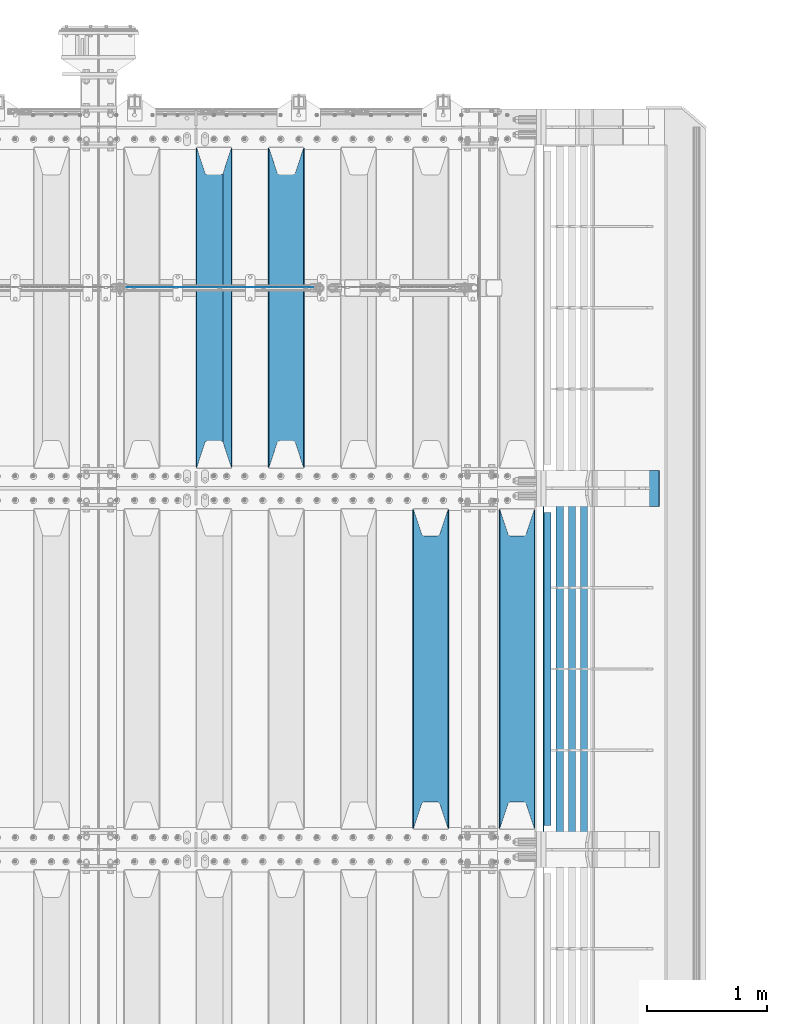
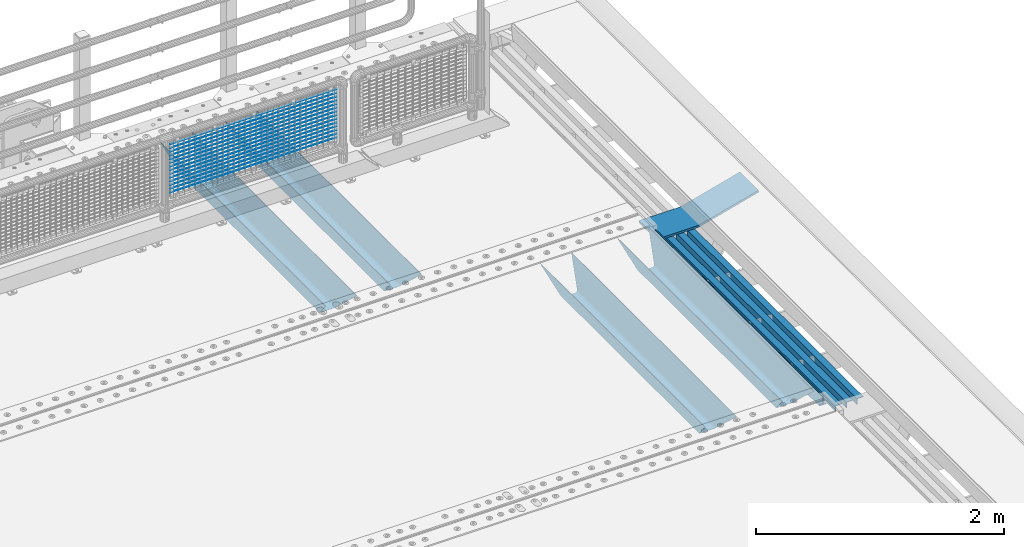
# One storey, part 124 of 240: 23 beams.
"""IFC2X3 building model written with IfcOpenShell, lengths in millimetres."""

from ifc_helpers import new_model, si_unit, frame, origin_with_axes, place, context, subcontext, project, spatial, faceted_brep, material, type_object, element, save


model = new_model("IFC2X3")

# Units and contexts
model_context = context("Model", 3, precision=1e-05, world=origin_with_axes())
body_context = subcontext(model_context, "Body", "Model", "MODEL_VIEW")
ifc_project = project(units=[si_unit("LENGTHUNIT", "METRE", prefix="MILLI"), si_unit("AREAUNIT", "SQUARE_METRE"), si_unit("VOLUMEUNIT", "CUBIC_METRE"), si_unit("MASSUNIT", "GRAM", prefix="KILO"), si_unit("TIMEUNIT", "SECOND"), si_unit("PLANEANGLEUNIT", "RADIAN"), si_unit("SOLIDANGLEUNIT", "STERADIAN"), si_unit("THERMODYNAMICTEMPERATUREUNIT", "DEGREE_CELSIUS"), si_unit("LUMINOUSINTENSITYUNIT", "LUMEN")], contexts=[model_context])

# Site, building, storey
site_placement = place(None, origin_with_axes())
site = spatial("IfcSite", under=ifc_project, at=site_placement, CompositionType="ELEMENT")
building_placement = place(site_placement, origin_with_axes())
building = spatial("IfcBuilding", under=site, at=building_placement, Name="Standard", CompositionType="ELEMENT")
storey_placement = place(building_placement, origin_with_axes())
storey = spatial("IfcBuildingStorey", under=building, at=storey_placement, Name="Undefined", CompositionType="ELEMENT", Elevation=0.0)

# Beams
ifc_material_1 = material(Name="STEEL/S355N")
beam_type_1 = type_object("IfcBeamType", PredefinedType="NOTDEFINED")
beam_1_placement = place(storey_placement, frame((56317.0, 30175.0, -115.0), z_axis=(0.0, 0.0, 1.0), x_axis=(0.0, 1.0, 0.0)))
element("IfcBeam", 1, at=beam_1_placement, inside=storey, type_object=beam_type_1, material=ifc_material_1, context=body_context, shape_type="Brep", body=[
    faceted_brep([(0.0, 150.0, 115.0), (0.0, 143.690000000002, 115.0), (2650.00000000297, 143.690000000002, 115.0), (2650.00000000297, 150.0, 115.0), (2650.00000000297, 142.059565218406, 110.000000003094), (2650.00000000297, 148.369565218403, 110.000000003094), (2441.90079219209, -80.1103600731149, -98.0992078077845), (2437.7588105432, -77.5672621345584, -102.241189456673), (2434.06523489747, -74.4080125315522, -105.934765102404), (2430.9108609509, -70.7102721255724, -109.089139048974), (2428.37322971128, -66.5649389910031, -111.626770288588), (2426.51472138055, -62.0739139532889, -113.485278619323), (2425.38102192092, -57.3475956567636, -114.618978078955), (2424.99999999987, -52.5021667386536, -115.0), (2424.99999999987, 52.5021667386536, -115.0), (2425.38102192092, 57.3475956567636, -114.618978078955), (2426.51472138055, 62.0739139532889, -113.485278619323), (2428.37322971128, 66.5649389910031, -111.626770288588), (2430.9108609509, 70.7102721255724, -109.089139048974), (2434.06523489747, 74.4080125315522, -105.934765102404), (2437.7588105432, 77.5672621345584, -102.241189456673), (2441.90079219209, 80.1103600731149, -98.0992078077846), (2446.38936140512, 81.9747917625791, -93.6106385947584), (2448.2494850041, 76.2713538057287, -91.7505149957729), (2444.62967112263, 74.76777986261, -95.3703288772456), (2441.28936334127, 72.7168944282894, -98.710636658607), (2438.31067330439, 70.1691124903809, -101.689326695487), (2435.76682334748, 67.1870637758839, -104.233176652398), (2433.72034654134, 63.8440531834931, -106.279653458539), (2432.22154950042, 60.2222587982324, -107.778450499454), (2431.30727574265, 56.4107117849126, -108.692724257221), (2430.99999999987, 52.5031078186876, -109.0), (2430.99999999987, -52.5031078186876, -109.0), (2431.30727574265, -56.4107117849126, -108.692724257221), (2432.22154950042, -60.2222587982324, -107.778450499454), (2433.72034654134, -63.8440531834931, -106.279653458539), (2435.76682334748, -67.1870637758839, -104.233176652398), (2438.31067330439, -70.1691124903809, -101.689326695487), (2441.28936334127, -72.7168944282894, -98.7106366586071), (2444.62967112263, -74.76777986261, -95.3703288772457), (2448.2494850041, -76.2713538057287, -91.7505149957729), (2650.00000000297, -142.059565218406, 110.000000003094), (2650.00000000297, -148.369565218403, 110.000000003094), (2446.38936140512, -81.9747917625791, -93.6106385947584), (2650.00000000297, -143.690000000002, 115.0), (2650.00000000297, -150.0, 115.0), (0.0, -143.690000000002, 115.0), (0.0, -150.0, 115.0), (0.0, -148.369565218258, 110.000000002667), (203.610638597427, -81.9747917625791, -93.6106385947584), (208.09920781045, -80.1103600731149, -98.0992078077845), (212.241189459342, -77.5672621345584, -102.241189456673), (215.93476510507, -74.4080125315522, -105.934765102404), (219.089139051641, -70.7102721255724, -109.089139048974), (221.626770291256, -66.5649389910031, -111.626770288588), (223.485278621989, -62.0739139532889, -113.485278619323), (224.618978081624, -57.3475956567636, -114.618978078955), (225.000000002663, -52.5021667386536, -115.0), (225.000000002663, 52.5021667386536, -115.0), (224.618978081624, 57.3475956567636, -114.618978078955), (223.485278621989, 62.0739139532889, -113.485278619323), (221.626770291256, 66.5649389910031, -111.626770288588), (219.089139051641, 70.7102721255724, -109.089139048974), (215.93476510507, 74.4080125315522, -105.934765102404), (212.241189459342, 77.5672621345584, -102.241189456673), (208.09920781045, 80.1103600731149, -98.0992078077846), (203.610638597427, 81.9747917625791, -93.6106385947584), (0.0, 148.369565218258, 110.000000002667), (0.0, 142.05956521826, 110.000000002667), (201.750514998439, 76.2713538057287, -91.7505149957729), (205.370328879908, 74.76777986261, -95.3703288772456), (208.710636661275, 72.7168944282894, -98.710636658607), (211.689326698153, 70.1691124903809, -101.689326695487), (214.233176655063, 67.1870637758839, -104.233176652398), (216.279653461206, 63.8440531834931, -106.279653458539), (217.778450502123, 60.2222587982324, -107.778450499454), (218.692724259887, 56.4107117849126, -108.692724257221), (219.000000002667, 52.5031078186876, -109.0), (219.000000002667, -52.5031078186876, -109.0), (218.692724259887, -56.4107117849126, -108.692724257221), (217.778450502123, -60.2222587982324, -107.778450499454), (216.279653461206, -63.8440531834931, -106.279653458539), (214.233176655063, -67.1870637758839, -104.233176652398), (211.689326698153, -70.1691124903809, -101.689326695487), (208.710636661275, -72.7168944282894, -98.7106366586071), (205.370328879915, -74.76777986261, -95.3703288772457), (201.750514998439, -76.2713538057287, -91.7505149957729), (0.0, -142.05956521826, 110.000000002667)], [[[0, 1, 2, 3]], [[3, 2, 4, 5]], [[6, 7, 8, 9, 10, 11, 12, 13, 14, 15, 16, 17, 18, 19, 20, 21, 22, 5, 4, 23, 24, 25, 26, 27, 28, 29, 30, 31, 32, 33, 34, 35, 36, 37, 38, 39, 40, 41, 42, 43]], [[44, 45, 42, 41]], [[46, 47, 45, 44]], [[43, 42, 45, 47, 48, 49]], [[6, 43, 49, 50]], [[7, 6, 50, 51]], [[8, 7, 51, 52]], [[9, 8, 52, 53]], [[10, 9, 53, 54]], [[11, 10, 54, 55]], [[12, 11, 55, 56]], [[13, 12, 56, 57]], [[14, 13, 57, 58]], [[15, 14, 58, 59]], [[16, 15, 59, 60]], [[17, 16, 60, 61]], [[18, 17, 61, 62]], [[19, 18, 62, 63]], [[20, 19, 63, 64]], [[21, 20, 64, 65]], [[22, 21, 65, 66]], [[0, 3, 5, 22, 66, 67]], [[1, 0, 67, 68]], [[23, 4, 2, 1, 68, 69]], [[24, 23, 69, 70]], [[25, 24, 70, 71]], [[26, 25, 71, 72]], [[27, 26, 72, 73]], [[28, 27, 73, 74]], [[29, 28, 74, 75]], [[30, 29, 75, 76]], [[31, 30, 76, 77]], [[32, 31, 77, 78]], [[33, 32, 78, 79]], [[34, 33, 79, 80]], [[35, 34, 80, 81]], [[36, 35, 81, 82]], [[37, 36, 82, 83]], [[38, 37, 83, 84]], [[39, 38, 84, 85]], [[40, 39, 85, 86]], [[46, 44, 41, 40, 86, 87]], [[47, 46, 87, 48]], [[86, 85, 84, 83, 82, 81, 80, 79, 78, 77, 76, 75, 74, 73, 72, 71, 70, 69, 68, 67, 66, 65, 64, 63, 62, 61, 60, 59, 58, 57, 56, 55, 54, 53, 52, 51, 50, 49, 48, 87]]]),
])
beam_2_placement = place(storey_placement, frame((55600.0, 30175.0, -115.0), z_axis=(0.0, 0.0, 1.0), x_axis=(0.0, 1.0, 0.0)))
element("IfcBeam", 2, at=beam_2_placement, inside=storey, type_object=beam_type_1, material=ifc_material_1, context=body_context, shape_type="Brep", body=[
    faceted_brep([(0.0, 150.0, 115.0), (0.0, 143.690000000002, 115.0), (2650.00000000297, 143.690000000002, 115.0), (2650.00000000297, 150.0, 115.0), (2650.00000000297, 142.059565218406, 110.000000003094), (2650.00000000297, 148.369565218403, 110.000000003094), (2441.90079219209, -80.1103600731149, -98.0992078077845), (2437.7588105432, -77.5672621345584, -102.241189456673), (2434.06523489747, -74.4080125315522, -105.934765102404), (2430.9108609509, -70.7102721255724, -109.089139048974), (2428.37322971128, -66.5649389910031, -111.626770288588), (2426.51472138055, -62.0739139532889, -113.485278619323), (2425.38102192092, -57.3475956567636, -114.618978078955), (2424.99999999987, -52.5021667386536, -115.0), (2424.99999999987, 52.5021667386536, -115.0), (2425.38102192092, 57.3475956567636, -114.618978078955), (2426.51472138055, 62.0739139532889, -113.485278619323), (2428.37322971128, 66.5649389910031, -111.626770288588), (2430.9108609509, 70.7102721255724, -109.089139048974), (2434.06523489747, 74.4080125315522, -105.934765102404), (2437.7588105432, 77.5672621345584, -102.241189456673), (2441.90079219209, 80.1103600731149, -98.0992078077846), (2446.38936140512, 81.9747917625791, -93.6106385947584), (2448.2494850041, 76.2713538057287, -91.7505149957729), (2444.62967112263, 74.76777986261, -95.3703288772456), (2441.28936334127, 72.7168944282894, -98.710636658607), (2438.31067330439, 70.1691124903809, -101.689326695487), (2435.76682334748, 67.1870637758839, -104.233176652398), (2433.72034654134, 63.8440531834931, -106.279653458539), (2432.22154950042, 60.2222587982324, -107.778450499454), (2431.30727574265, 56.4107117849126, -108.692724257221), (2430.99999999987, 52.5031078186876, -109.0), (2430.99999999987, -52.5031078186876, -109.0), (2431.30727574265, -56.4107117849126, -108.692724257221), (2432.22154950042, -60.2222587982324, -107.778450499454), (2433.72034654134, -63.8440531834931, -106.279653458539), (2435.76682334748, -67.1870637758839, -104.233176652398), (2438.31067330439, -70.1691124903809, -101.689326695487), (2441.28936334127, -72.7168944282894, -98.7106366586071), (2444.62967112263, -74.76777986261, -95.3703288772457), (2448.2494850041, -76.2713538057287, -91.7505149957729), (2650.00000000297, -142.059565218406, 110.000000003094), (2650.00000000297, -148.369565218403, 110.000000003094), (2446.38936140512, -81.9747917625791, -93.6106385947584), (2650.00000000297, -143.690000000002, 115.0), (2650.00000000297, -150.0, 115.0), (0.0, -143.690000000002, 115.0), (0.0, -150.0, 115.0), (0.0, -148.369565218258, 110.000000002667), (203.610638597427, -81.9747917625791, -93.6106385947584), (208.09920781045, -80.1103600731149, -98.0992078077845), (212.241189459342, -77.5672621345584, -102.241189456673), (215.93476510507, -74.4080125315522, -105.934765102404), (219.089139051641, -70.7102721255724, -109.089139048974), (221.626770291256, -66.5649389910031, -111.626770288588), (223.485278621989, -62.0739139532889, -113.485278619323), (224.618978081624, -57.3475956567636, -114.618978078955), (225.000000002663, -52.5021667386536, -115.0), (225.000000002663, 52.5021667386536, -115.0), (224.618978081624, 57.3475956567636, -114.618978078955), (223.485278621989, 62.0739139532889, -113.485278619323), (221.626770291256, 66.5649389910031, -111.626770288588), (219.089139051641, 70.7102721255724, -109.089139048974), (215.93476510507, 74.4080125315522, -105.934765102404), (212.241189459342, 77.5672621345584, -102.241189456673), (208.09920781045, 80.1103600731149, -98.0992078077846), (203.610638597427, 81.9747917625791, -93.6106385947584), (0.0, 148.369565218258, 110.000000002667), (0.0, 142.05956521826, 110.000000002667), (201.750514998439, 76.2713538057287, -91.7505149957729), (205.370328879908, 74.76777986261, -95.3703288772456), (208.710636661275, 72.7168944282894, -98.710636658607), (211.689326698153, 70.1691124903809, -101.689326695487), (214.233176655063, 67.1870637758839, -104.233176652398), (216.279653461206, 63.8440531834931, -106.279653458539), (217.778450502123, 60.2222587982324, -107.778450499454), (218.692724259887, 56.4107117849126, -108.692724257221), (219.000000002667, 52.5031078186876, -109.0), (219.000000002667, -52.5031078186876, -109.0), (218.692724259887, -56.4107117849126, -108.692724257221), (217.778450502123, -60.2222587982324, -107.778450499454), (216.279653461206, -63.8440531834931, -106.279653458539), (214.233176655063, -67.1870637758839, -104.233176652398), (211.689326698153, -70.1691124903809, -101.689326695487), (208.710636661275, -72.7168944282894, -98.7106366586071), (205.370328879915, -74.76777986261, -95.3703288772457), (201.750514998439, -76.2713538057287, -91.7505149957729), (0.0, -142.05956521826, 110.000000002667)], [[[0, 1, 2, 3]], [[3, 2, 4, 5]], [[6, 7, 8, 9, 10, 11, 12, 13, 14, 15, 16, 17, 18, 19, 20, 21, 22, 5, 4, 23, 24, 25, 26, 27, 28, 29, 30, 31, 32, 33, 34, 35, 36, 37, 38, 39, 40, 41, 42, 43]], [[44, 45, 42, 41]], [[46, 47, 45, 44]], [[43, 42, 45, 47, 48, 49]], [[6, 43, 49, 50]], [[7, 6, 50, 51]], [[8, 7, 51, 52]], [[9, 8, 52, 53]], [[10, 9, 53, 54]], [[11, 10, 54, 55]], [[12, 11, 55, 56]], [[13, 12, 56, 57]], [[14, 13, 57, 58]], [[15, 14, 58, 59]], [[16, 15, 59, 60]], [[17, 16, 60, 61]], [[18, 17, 61, 62]], [[19, 18, 62, 63]], [[20, 19, 63, 64]], [[21, 20, 64, 65]], [[22, 21, 65, 66]], [[0, 3, 5, 22, 66, 67]], [[1, 0, 67, 68]], [[23, 4, 2, 1, 68, 69]], [[24, 23, 69, 70]], [[25, 24, 70, 71]], [[26, 25, 71, 72]], [[27, 26, 72, 73]], [[28, 27, 73, 74]], [[29, 28, 74, 75]], [[30, 29, 75, 76]], [[31, 30, 76, 77]], [[32, 31, 77, 78]], [[33, 32, 78, 79]], [[34, 33, 79, 80]], [[35, 34, 80, 81]], [[36, 35, 81, 82]], [[37, 36, 82, 83]], [[38, 37, 83, 84]], [[39, 38, 84, 85]], [[40, 39, 85, 86]], [[46, 44, 41, 40, 86, 87]], [[47, 46, 87, 48]], [[86, 85, 84, 83, 82, 81, 80, 79, 78, 77, 76, 75, 74, 73, 72, 71, 70, 69, 68, 67, 66, 65, 64, 63, 62, 61, 60, 59, 58, 57, 56, 55, 54, 53, 52, 51, 50, 49, 48, 87]]]),
])
beam_3_placement = place(storey_placement, frame((54400.0, 33175.0, -115.0), z_axis=(0.0, 0.0, 1.0), x_axis=(0.0, 1.0, 0.0)))
element("IfcBeam", 3, at=beam_3_placement, inside=storey, type_object=beam_type_1, material=ifc_material_1, context=body_context, shape_type="Brep", body=[
    faceted_brep([(0.0, 150.0, 115.0), (0.0, 143.690000000002, 115.0), (2650.00000000297, 143.690000000002, 115.0), (2650.00000000297, 150.0, 115.0), (2650.00000000297, 142.059565218406, 110.000000003094), (2650.00000000297, 148.369565218403, 110.000000003094), (2441.90079219209, -80.1103600731149, -98.0992078077845), (2437.7588105432, -77.5672621345584, -102.241189456673), (2434.06523489747, -74.4080125315522, -105.934765102404), (2430.9108609509, -70.7102721255724, -109.089139048974), (2428.37322971128, -66.5649389910031, -111.626770288588), (2426.51472138055, -62.0739139532889, -113.485278619323), (2425.38102192092, -57.3475956567636, -114.618978078955), (2424.99999999987, -52.5021667386536, -115.0), (2424.99999999987, 52.5021667386536, -115.0), (2425.38102192092, 57.3475956567636, -114.618978078955), (2426.51472138055, 62.0739139532889, -113.485278619323), (2428.37322971128, 66.5649389910031, -111.626770288588), (2430.9108609509, 70.7102721255724, -109.089139048974), (2434.06523489747, 74.4080125315522, -105.934765102404), (2437.7588105432, 77.5672621345584, -102.241189456673), (2441.90079219209, 80.1103600731149, -98.0992078077846), (2446.38936140512, 81.9747917625791, -93.6106385947584), (2448.2494850041, 76.2713538057287, -91.7505149957729), (2444.62967112263, 74.76777986261, -95.3703288772456), (2441.28936334127, 72.7168944282894, -98.710636658607), (2438.31067330439, 70.1691124903809, -101.689326695487), (2435.76682334748, 67.1870637758839, -104.233176652398), (2433.72034654134, 63.8440531834931, -106.279653458539), (2432.22154950042, 60.2222587982324, -107.778450499454), (2431.30727574265, 56.4107117849126, -108.692724257221), (2430.99999999987, 52.5031078186876, -109.0), (2430.99999999987, -52.5031078186876, -109.0), (2431.30727574265, -56.4107117849126, -108.692724257221), (2432.22154950042, -60.2222587982324, -107.778450499454), (2433.72034654134, -63.8440531834931, -106.279653458539), (2435.76682334748, -67.1870637758839, -104.233176652398), (2438.31067330439, -70.1691124903809, -101.689326695487), (2441.28936334127, -72.7168944282894, -98.7106366586071), (2444.62967112263, -74.76777986261, -95.3703288772457), (2448.2494850041, -76.2713538057287, -91.7505149957729), (2650.00000000297, -142.059565218406, 110.000000003094), (2650.00000000297, -148.369565218403, 110.000000003094), (2446.38936140512, -81.9747917625791, -93.6106385947584), (2650.00000000297, -143.690000000002, 115.0), (2650.00000000297, -150.0, 115.0), (0.0, -143.690000000002, 115.0), (0.0, -150.0, 115.0), (0.0, -148.369565218258, 110.000000002667), (203.610638597427, -81.9747917625791, -93.6106385947584), (208.09920781045, -80.1103600731149, -98.0992078077845), (212.241189459342, -77.5672621345584, -102.241189456673), (215.93476510507, -74.4080125315522, -105.934765102404), (219.089139051641, -70.7102721255724, -109.089139048974), (221.626770291256, -66.5649389910031, -111.626770288588), (223.485278621989, -62.0739139532889, -113.485278619323), (224.618978081624, -57.3475956567636, -114.618978078955), (225.000000002663, -52.5021667386536, -115.0), (225.000000002663, 52.5021667386536, -115.0), (224.618978081624, 57.3475956567636, -114.618978078955), (223.485278621989, 62.0739139532889, -113.485278619323), (221.626770291256, 66.5649389910031, -111.626770288588), (219.089139051641, 70.7102721255724, -109.089139048974), (215.93476510507, 74.4080125315522, -105.934765102404), (212.241189459342, 77.5672621345584, -102.241189456673), (208.09920781045, 80.1103600731149, -98.0992078077846), (203.610638597427, 81.9747917625791, -93.6106385947584), (0.0, 148.369565218258, 110.000000002667), (0.0, 142.05956521826, 110.000000002667), (201.750514998439, 76.2713538057287, -91.7505149957729), (205.370328879908, 74.76777986261, -95.3703288772456), (208.710636661275, 72.7168944282894, -98.710636658607), (211.689326698153, 70.1691124903809, -101.689326695487), (214.233176655063, 67.1870637758839, -104.233176652398), (216.279653461206, 63.8440531834931, -106.279653458539), (217.778450502123, 60.2222587982324, -107.778450499454), (218.692724259887, 56.4107117849126, -108.692724257221), (219.000000002667, 52.5031078186876, -109.0), (219.000000002667, -52.5031078186876, -109.0), (218.692724259887, -56.4107117849126, -108.692724257221), (217.778450502123, -60.2222587982324, -107.778450499454), (216.279653461206, -63.8440531834931, -106.279653458539), (214.233176655063, -67.1870637758839, -104.233176652398), (211.689326698153, -70.1691124903809, -101.689326695487), (208.710636661275, -72.7168944282894, -98.7106366586071), (205.370328879915, -74.76777986261, -95.3703288772457), (201.750514998439, -76.2713538057287, -91.7505149957729), (0.0, -142.05956521826, 110.000000002667)], [[[0, 1, 2, 3]], [[3, 2, 4, 5]], [[6, 7, 8, 9, 10, 11, 12, 13, 14, 15, 16, 17, 18, 19, 20, 21, 22, 5, 4, 23, 24, 25, 26, 27, 28, 29, 30, 31, 32, 33, 34, 35, 36, 37, 38, 39, 40, 41, 42, 43]], [[44, 45, 42, 41]], [[46, 47, 45, 44]], [[43, 42, 45, 47, 48, 49]], [[6, 43, 49, 50]], [[7, 6, 50, 51]], [[8, 7, 51, 52]], [[9, 8, 52, 53]], [[10, 9, 53, 54]], [[11, 10, 54, 55]], [[12, 11, 55, 56]], [[13, 12, 56, 57]], [[14, 13, 57, 58]], [[15, 14, 58, 59]], [[16, 15, 59, 60]], [[17, 16, 60, 61]], [[18, 17, 61, 62]], [[19, 18, 62, 63]], [[20, 19, 63, 64]], [[21, 20, 64, 65]], [[22, 21, 65, 66]], [[0, 3, 5, 22, 66, 67]], [[1, 0, 67, 68]], [[23, 4, 2, 1, 68, 69]], [[24, 23, 69, 70]], [[25, 24, 70, 71]], [[26, 25, 71, 72]], [[27, 26, 72, 73]], [[28, 27, 73, 74]], [[29, 28, 74, 75]], [[30, 29, 75, 76]], [[31, 30, 76, 77]], [[32, 31, 77, 78]], [[33, 32, 78, 79]], [[34, 33, 79, 80]], [[35, 34, 80, 81]], [[36, 35, 81, 82]], [[37, 36, 82, 83]], [[38, 37, 83, 84]], [[39, 38, 84, 85]], [[40, 39, 85, 86]], [[46, 44, 41, 40, 86, 87]], [[47, 46, 87, 48]], [[86, 85, 84, 83, 82, 81, 80, 79, 78, 77, 76, 75, 74, 73, 72, 71, 70, 69, 68, 67, 66, 65, 64, 63, 62, 61, 60, 59, 58, 57, 56, 55, 54, 53, 52, 51, 50, 49, 48, 87]]]),
])
beam_4_placement = place(storey_placement, frame((53800.0, 33175.0, -115.0), z_axis=(0.0, 0.0, 1.0), x_axis=(0.0, 1.0, 0.0)))
element("IfcBeam", 4, at=beam_4_placement, inside=storey, type_object=beam_type_1, material=ifc_material_1, context=body_context, shape_type="Brep", body=[
    faceted_brep([(0.0, 150.0, 115.0), (0.0, 143.690000000002, 115.0), (2650.00000000297, 143.690000000002, 115.0), (2650.00000000297, 150.0, 115.0), (2650.00000000297, 142.059565218406, 110.000000003094), (2650.00000000297, 148.369565218403, 110.000000003094), (2441.90079219209, -80.1103600731149, -98.0992078077845), (2437.7588105432, -77.5672621345584, -102.241189456673), (2434.06523489747, -74.4080125315522, -105.934765102404), (2430.9108609509, -70.7102721255724, -109.089139048974), (2428.37322971128, -66.5649389910031, -111.626770288588), (2426.51472138055, -62.0739139532889, -113.485278619323), (2425.38102192092, -57.3475956567636, -114.618978078955), (2424.99999999987, -52.5021667386536, -115.0), (2424.99999999987, 52.5021667386536, -115.0), (2425.38102192092, 57.3475956567636, -114.618978078955), (2426.51472138055, 62.0739139532889, -113.485278619323), (2428.37322971128, 66.5649389910031, -111.626770288588), (2430.9108609509, 70.7102721255724, -109.089139048974), (2434.06523489747, 74.4080125315522, -105.934765102404), (2437.7588105432, 77.5672621345584, -102.241189456673), (2441.90079219209, 80.1103600731149, -98.0992078077846), (2446.38936140512, 81.9747917625791, -93.6106385947584), (2448.2494850041, 76.2713538057287, -91.7505149957729), (2444.62967112263, 74.76777986261, -95.3703288772456), (2441.28936334127, 72.7168944282894, -98.710636658607), (2438.31067330439, 70.1691124903809, -101.689326695487), (2435.76682334748, 67.1870637758839, -104.233176652398), (2433.72034654134, 63.8440531834931, -106.279653458539), (2432.22154950042, 60.2222587982324, -107.778450499454), (2431.30727574265, 56.4107117849126, -108.692724257221), (2430.99999999987, 52.5031078186876, -109.0), (2430.99999999987, -52.5031078186876, -109.0), (2431.30727574265, -56.4107117849126, -108.692724257221), (2432.22154950042, -60.2222587982324, -107.778450499454), (2433.72034654134, -63.8440531834931, -106.279653458539), (2435.76682334748, -67.1870637758839, -104.233176652398), (2438.31067330439, -70.1691124903809, -101.689326695487), (2441.28936334127, -72.7168944282894, -98.7106366586071), (2444.62967112263, -74.76777986261, -95.3703288772457), (2448.2494850041, -76.2713538057287, -91.7505149957729), (2650.00000000297, -142.059565218406, 110.000000003094), (2650.00000000297, -148.369565218403, 110.000000003094), (2446.38936140512, -81.9747917625791, -93.6106385947584), (2650.00000000297, -143.690000000002, 115.0), (2650.00000000297, -150.0, 115.0), (0.0, -143.690000000002, 115.0), (0.0, -150.0, 115.0), (0.0, -148.369565218258, 110.000000002667), (203.610638597427, -81.9747917625791, -93.6106385947584), (208.09920781045, -80.1103600731149, -98.0992078077845), (212.241189459342, -77.5672621345584, -102.241189456673), (215.93476510507, -74.4080125315522, -105.934765102404), (219.089139051641, -70.7102721255724, -109.089139048974), (221.626770291256, -66.5649389910031, -111.626770288588), (223.485278621989, -62.0739139532889, -113.485278619323), (224.618978081624, -57.3475956567636, -114.618978078955), (225.000000002663, -52.5021667386536, -115.0), (225.000000002663, 52.5021667386536, -115.0), (224.618978081624, 57.3475956567636, -114.618978078955), (223.485278621989, 62.0739139532889, -113.485278619323), (221.626770291256, 66.5649389910031, -111.626770288588), (219.089139051641, 70.7102721255724, -109.089139048974), (215.93476510507, 74.4080125315522, -105.934765102404), (212.241189459342, 77.5672621345584, -102.241189456673), (208.09920781045, 80.1103600731149, -98.0992078077846), (203.610638597427, 81.9747917625791, -93.6106385947584), (0.0, 148.369565218258, 110.000000002667), (0.0, 142.05956521826, 110.000000002667), (201.750514998439, 76.2713538057287, -91.7505149957729), (205.370328879908, 74.76777986261, -95.3703288772456), (208.710636661275, 72.7168944282894, -98.710636658607), (211.689326698153, 70.1691124903809, -101.689326695487), (214.233176655063, 67.1870637758839, -104.233176652398), (216.279653461206, 63.8440531834931, -106.279653458539), (217.778450502123, 60.2222587982324, -107.778450499454), (218.692724259887, 56.4107117849126, -108.692724257221), (219.000000002667, 52.5031078186876, -109.0), (219.000000002667, -52.5031078186876, -109.0), (218.692724259887, -56.4107117849126, -108.692724257221), (217.778450502123, -60.2222587982324, -107.778450499454), (216.279653461206, -63.8440531834931, -106.279653458539), (214.233176655063, -67.1870637758839, -104.233176652398), (211.689326698153, -70.1691124903809, -101.689326695487), (208.710636661275, -72.7168944282894, -98.7106366586071), (205.370328879915, -74.76777986261, -95.3703288772457), (201.750514998439, -76.2713538057287, -91.7505149957729), (0.0, -142.05956521826, 110.000000002667)], [[[0, 1, 2, 3]], [[3, 2, 4, 5]], [[6, 7, 8, 9, 10, 11, 12, 13, 14, 15, 16, 17, 18, 19, 20, 21, 22, 5, 4, 23, 24, 25, 26, 27, 28, 29, 30, 31, 32, 33, 34, 35, 36, 37, 38, 39, 40, 41, 42, 43]], [[44, 45, 42, 41]], [[46, 47, 45, 44]], [[43, 42, 45, 47, 48, 49]], [[6, 43, 49, 50]], [[7, 6, 50, 51]], [[8, 7, 51, 52]], [[9, 8, 52, 53]], [[10, 9, 53, 54]], [[11, 10, 54, 55]], [[12, 11, 55, 56]], [[13, 12, 56, 57]], [[14, 13, 57, 58]], [[15, 14, 58, 59]], [[16, 15, 59, 60]], [[17, 16, 60, 61]], [[18, 17, 61, 62]], [[19, 18, 62, 63]], [[20, 19, 63, 64]], [[21, 20, 64, 65]], [[22, 21, 65, 66]], [[0, 3, 5, 22, 66, 67]], [[1, 0, 67, 68]], [[23, 4, 2, 1, 68, 69]], [[24, 23, 69, 70]], [[25, 24, 70, 71]], [[26, 25, 71, 72]], [[27, 26, 72, 73]], [[28, 27, 73, 74]], [[29, 28, 74, 75]], [[30, 29, 75, 76]], [[31, 30, 76, 77]], [[32, 31, 77, 78]], [[33, 32, 78, 79]], [[34, 33, 79, 80]], [[35, 34, 80, 81]], [[36, 35, 81, 82]], [[37, 36, 82, 83]], [[38, 37, 83, 84]], [[39, 38, 84, 85]], [[40, 39, 85, 86]], [[46, 44, 41, 40, 86, 87]], [[47, 46, 87, 48]], [[86, 85, 84, 83, 82, 81, 80, 79, 78, 77, 76, 75, 74, 73, 72, 71, 70, 69, 68, 67, 66, 65, 64, 63, 62, 61, 60, 59, 58, 57, 56, 55, 54, 53, 52, 51, 50, 49, 48, 87]]]),
])
ifc_material_2 = material(Name="Misc_Undefined")
beam_type_2 = type_object("IfcBeamType", Name="D3", PredefinedType="NOTDEFINED")
for number, where, z_axis, x_axis in (
    (5, (53074.0, 34670.5, 851.597000000001), (0.0, 0.0, 1.0), (1.0, 0.0, 0.0)),
    (6, (53074.0, 34670.5, 669.452000000001), (0.0, 0.0, 1.0), (1.0, 0.0, 0.0)),
    (7, (53074.0, 34670.5, 523.736000000001), (0.0, 0.0, 1.0), (1.0, 0.0, 0.0)),
    (8, (53074.0, 34670.5, 487.307000000001), (0.0, 0.0, 1.0), (1.0, 0.0, 0.0)),
    (9, (53074.0, 34670.5, 705.881000000001), (0.0, 0.0, 1.0), (1.0, 0.0, 0.0)),
    (10, (53074.0, 34670.5, 596.594000000001), (0.0, 0.0, 1.0), (1.0, 0.0, 0.0)),
    (11, (53074.0, 34670.5, 450.878000000001), (0.0, 0.0, 1.0), (1.0, 0.0, 0.0)),
    (12, (53074.0, 34670.5, 815.168000000001), (0.0, 0.0, 1.0), (1.0, 0.0, 0.0)),
    (13, (53074.0, 34670.5, 888.026000000001), (0.0, 0.0, 1.0), (1.0, 0.0, 0.0)),
    (14, (53074.0, 34670.5, 778.739000000001), (0.0, 0.0, 1.0), (1.0, 0.0, 0.0)),
    (15, (53074.0, 34670.5, 742.310000000001), (0.0, 0.0, 1.0), (1.0, 0.0, 0.0)),
    (16, (53074.0, 34670.5, 633.023000000001), (0.0, 0.0, 1.0), (1.0, 0.0, 0.0)),
    (17, (53074.0, 34670.5, 560.165000000001), (0.0, 0.0, 1.0), (1.0, 0.0, 0.0)),
    (18, (53074.0, 34670.5, 414.449000000001), (0.0, 0.0, 1.0), (1.0, 0.0, 0.0)),
):
    element("IfcBeam", number, at=place(storey_placement, frame(where, z_axis=z_axis, x_axis=x_axis)), inside=storey, type_object=beam_type_2, material=ifc_material_2, ObjectType="D3", context=body_context, shape_type="Brep", body=[
        faceted_brep([(-7.27595761418343e-12, -1.49999999999272, 0.0), (-7.27595761418343e-12, -0.749999999992724, -1.29903810567669), (1548.0, -0.75, -1.29903810567669), (1548.0, -1.5, 0.0), (0.0, 0.750000000007276, -1.29903810567669), (1548.0, 0.75, -1.29903810567669), (0.0, 1.50000000000728, 0.0), (1548.0, 1.5, 0.0), (0.0, 0.750000000007276, 1.29903810567669), (1548.0, 0.75, 1.29903810567669), (-7.27595761418343e-12, -0.749999999992724, 1.29903810567669), (1548.0, -0.75, 1.29903810567669)], [[[0, 1, 2, 3]], [[1, 4, 5, 2]], [[4, 6, 7, 5]], [[6, 8, 9, 7]], [[8, 10, 11, 9]], [[10, 0, 3, 11]], [[5, 7, 9, 11, 3, 2]], [[10, 8, 6, 4, 1, 0]]]),
    ])
ifc_material_3 = material(Name="STEEL/S355J2")
beam_type_3 = type_object("IfcBeamType", PredefinedType="NOTDEFINED")
beam_5_placement = place(storey_placement, frame((56564.5025260065, 30150.0, -124.999999999985), z_axis=(0.0, 0.0, 1.0), x_axis=(0.0, 1.0, 0.0)))
element("IfcBeam", 19, at=beam_5_placement, inside=storey, type_object=beam_type_3, material=ifc_material_3, context=body_context, shape_type="Brep", body=[
    faceted_brep([(2700.0, 22.5, -15.0), (2684.54915028125, 22.5, -17.4471741852423), (2684.54915028125, 32.4999999999927, -17.4471741852423), (2700.0, 32.5, -15.0), (2670.61073738538, 22.5, -24.5491502812526), (2670.61073738538, 32.4999999999927, -24.5491502812526), (2659.54915028125, 22.5, -35.6107373853764), (2659.54915028125, 32.4999999999927, -35.6107373853764), (2652.44717418524, 22.5, -49.5491502812526), (2652.44717418524, 32.4999999999927, -49.5491502812526), (2651.58384440325, -32.5, -55.0), (2650.0, -32.5, -65.0), (2650.0, 32.5, -65.0), (2651.58384440325, 22.5, -55.0), (0.0, 32.5, 65.0), (0.0, 22.5, 65.0), (2700.0, 22.5, 65.0), (2700.0, 32.5, 65.0), (0.0, 32.5, -15.0), (0.0, 22.5, -15.0), (15.4508497187489, 32.5, -17.4471741852423), (15.4508497187489, 22.5, -17.4471741852423), (29.3892626146226, 32.5, -24.5491502812526), (29.3892626146226, 22.5, -24.5491502812526), (40.4508497187489, 32.5, -35.6107373853763), (40.4508497187489, 22.5, -35.6107373853763), (47.5528258147569, 32.5, -49.5491502812526), (47.5528258147569, 22.5, -49.5491502812526), (50.0, -32.5, -65.0), (48.4161555967512, -32.5, -55.0), (48.4161555967512, 22.5, -55.0), (50.0, 32.5, -65.0)], [[[0, 1, 2, 3]], [[4, 5, 2, 1]], [[6, 7, 5, 4]], [[8, 9, 7, 6]], [[10, 11, 12, 9, 8, 13]], [[14, 15, 16, 17]], [[15, 14, 18, 19]], [[19, 18, 20, 21]], [[21, 20, 22, 23]], [[23, 22, 24, 25]], [[25, 24, 26, 27]], [[28, 29, 30, 27, 26, 31]], [[30, 29, 10, 13]], [[16, 15, 19, 21, 23, 25, 27, 30, 13, 8, 6, 4, 1, 0]], [[17, 16, 0, 3]], [[5, 7, 9, 12, 31, 26, 24, 22, 20, 18, 14, 17, 3, 2]], [[28, 31, 12, 11]], [[29, 28, 11, 10]]]),
])
beam_type_4 = type_object("IfcBeamType", PredefinedType="NOTDEFINED")
beam_6_placement = place(storey_placement, frame((56556.9988298906, 33000.0, -169.999999999995), z_axis=(0.0, -1.0, 0.0), x_axis=(1.0, 0.0, 0.0)))
element("IfcBeam", 20, at=beam_6_placement, inside=storey, type_object=beam_type_4, material=ifc_material_1, context=body_context, shape_type="Brep", body=[
    faceted_brep([(0.0, 10.0, -150.0), (0.0, 10.0, 150.0), (356.495387467709, 10.0, 150.0), (356.495387467716, 10.0000000000045, -150.0), (0.0, -10.0, 150.0), (0.0, -10.0, -150.0), (356.495387467709, -10.0, -150.0), (356.495387467709, -10.0, 150.0), (382.770279632619, 11.7334369042659, 150.0), (382.770279632619, 11.7334369042659, -150.0), (385.397768849085, -8.09321940530759, -150.0), (385.397768849085, -8.09321940530759, 150.0), (413.799145685371, -2.40593045938311, -150.0), (413.799145685371, -2.40593045938311, 150.0), (408.589713120156, 16.903699582373, 150.0), (408.589713119858, 16.9036995827009, -150.0), (938.999999999978, 160.0, 150.0), (938.999999999978, 160.0, -150.0), (944.209432565192, 140.69036995827, 150.0), (944.209432565192, 140.69036995827, -150.0)], [[[0, 1, 2, 3]], [[4, 5, 6, 7]], [[5, 4, 1, 0]], [[3, 2, 8, 9]], [[7, 6, 10, 11]], [[10, 12, 13, 11]], [[8, 14, 15, 9]], [[15, 14, 16, 17]], [[14, 8, 2, 1, 4, 7, 11, 13, 18, 16]], [[13, 12, 19, 18]], [[12, 10, 6, 5, 0, 3, 9, 15, 17, 19]], [[18, 19, 17, 16]]]),
])
beam_type_5 = type_object("IfcBeamType", PredefinedType="NOTDEFINED")
for number, where, z_axis, x_axis in (
    (21, (56872.0025260169, 32869.9999003886, -209.999999999563), (0.0, 0.0, -1.0), (0.0, -1.0, 0.0)),
    (22, (56772.0025260169, 32869.9999003886, -209.999999999563), (0.0, 0.0, -1.0), (0.0, -1.0, 0.0)),
    (23, (56672.0025260162, 32870.0000023132, -209.999999999622), (0.0, 0.0, -1.0), (0.0, -1.0, 0.0)),
):
    element("IfcBeam", number, at=place(storey_placement, frame(where, z_axis=z_axis, x_axis=x_axis)), inside=storey, type_object=beam_type_5, material=ifc_material_3, context=body_context, shape_type="Brep", body=[
        faceted_brep([(-3.63797880709171e-12, 29.9999999999927, -29.9999999999999), (-3.63797880709171e-12, 29.9999999999927, 30.0000000000001), (2740.00017042501, 29.9999999999927, 30.0000000000001), (2740.00017042501, 29.9999999999927, -29.9999999999999), (-3.63797880709171e-12, 23.9999999999927, 30.0), (2740.00017042501, 23.9999999999927, 30.0), (-3.63797880709171e-12, 23.9999999999927, -24.0), (2740.00017042501, 23.9999999999927, -24.0), (-7.27595761418343e-12, -30.0000000000073, -24.0), (2740.00017042501, -30.0000000000073, -24.0), (-3.63797880709171e-12, -30.0000000000073, -30.0), (2740.00017042501, -30.0000000000073, -30.0)], [[[0, 1, 2, 3]], [[1, 4, 5, 2]], [[4, 6, 7, 5]], [[6, 8, 9, 7]], [[8, 10, 11, 9]], [[10, 0, 3, 11]], [[5, 7, 9, 11, 3, 2]], [[10, 8, 6, 4, 1, 0]]]),
    ])

save(model, "model.ifc")
